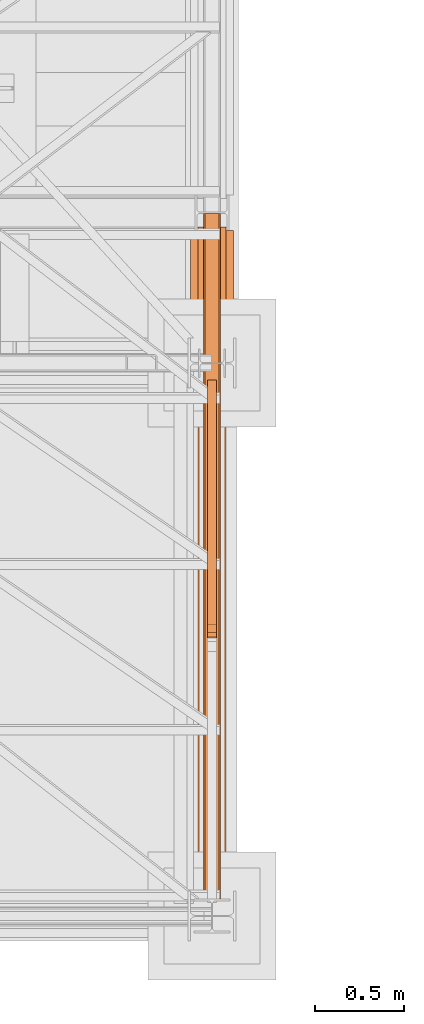
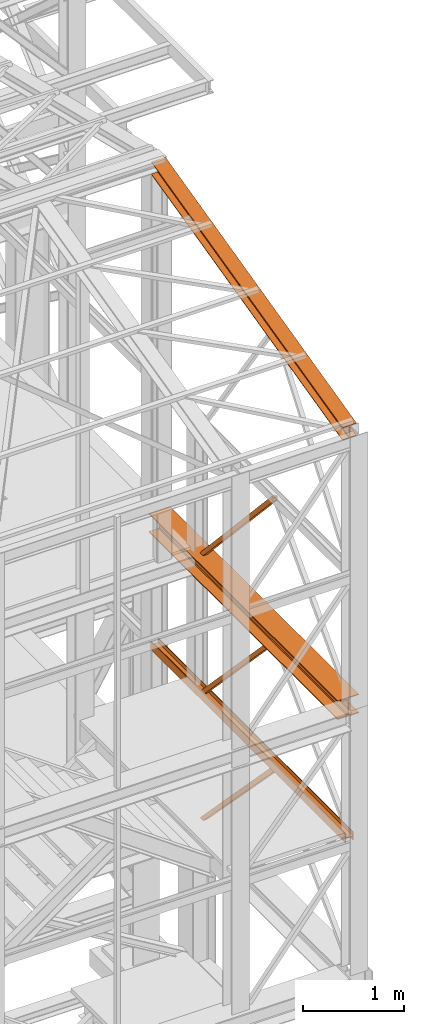
# One storey, part 58 of 208: 6 proxies.
"""IFC2X3 building model written with IfcOpenShell, lengths in millimetres."""

from ifc_helpers import new_model, entity, si_unit, converted_unit, frame, origin, origin_with_axes, place, context, subcontext, project, spatial, faceted_brep, element, save


model = new_model("IFC2X3")

# Units and contexts
model_context = context("Model", 3, precision=1e-05, world=origin())
plan_context = context("Plan", 3, precision=1e-05, world=origin())
body_context = subcontext(model_context, "Body", "Model", "MODEL_VIEW")
ifc_project = project(units=[si_unit("LENGTHUNIT", "METRE", prefix="MILLI"), converted_unit("PLANEANGLEUNIT", "DEGREE", entity("IfcPlaneAngleMeasure", 0.0174532925199433), si_unit("PLANEANGLEUNIT", "RADIAN"), dimensions=[0, 0, 0, 0, 0, 0, 0]), si_unit("AREAUNIT", "SQUARE_METRE"), si_unit("VOLUMEUNIT", "CUBIC_METRE")], contexts=[model_context, plan_context])

# Building, storey
building_placement = place(None, origin())
building = spatial("IfcBuilding", under=ifc_project, at=building_placement, CompositionType="COMPLEX")
storey_placement = place(building_placement, origin_with_axes())
storey = spatial("IfcBuildingStorey", under=building, at=storey_placement, Name="Geschoss", CompositionType="ELEMENT")

# Proxies
proxy_1_placement = place(storey_placement, frame((6650.25496814422, -25077.57437538435, 6759.989999254943), z_axis=(0.0, 0.0, 1.0), x_axis=(1.0, 0.0, 0.0)))
element("IfcBuildingElementProxy", 1, at=proxy_1_placement, inside=storey, context=body_context, shape_type="Brep", body=[
    faceted_brep([(8.010000000000218, 0.00999999999839929, 0.01000000000021828), (0.01000000000021828, 0.00999999999839929, 0.01000000000021828), (0.01000000000021828, 0.00999999999839929, 100.0100000000002), (8.010000000000218, 0.00999999999839929, 100.0100000000002), (8.010000000000218, 0.00999999999839929, 52.51000000000022), (88.01000000000022, 0.00999999999839929, 52.51000000000022), (88.01000000000022, 0.00999999999839929, 100.0100000000002), (96.00999999999931, 0.00999999999839929, 100.0100000000002), (96.00999999999931, 0.00999999999839929, 0.01000000000021828), (88.01000000000022, 0.00999999999839929, 0.01000000000021828), (88.01000000000022, 0.00999999999839929, 47.51000000000022), (8.010000000000218, 0.00999999999839929, 47.51000000000022), (0.01000000000021828, 0.00999999999839929, 0.01000000000021828), (8.010000000000218, 0.00999999999839929, 0.01000000000021828), (8.010000000000218, 3856.759984999411, 0.01000000000021828), (0.01000000000021828, 3856.759984999411, 0.01000000000021828), (0.01000000000021828, 0.00999999999839929, 100.0100000000002), (0.01000000000021828, 0.00999999999839929, 0.01000000000021828), (0.01000000000021828, 3856.759984999411, 0.01000000000021828), (0.01000000000021828, 3856.759984999411, 100.0100000000002), (8.010000000000218, 0.00999999999839929, 100.0100000000002), (0.01000000000021828, 0.00999999999839929, 100.0100000000002), (0.01000000000021828, 3856.759984999411, 100.0100000000002), (8.010000000000218, 3856.759984999411, 100.0100000000002), (8.010000000000218, 0.00999999999839929, 52.51000000000022), (8.010000000000218, 0.00999999999839929, 100.0100000000002), (8.010000000000218, 3856.759984999411, 100.0100000000002), (8.010000000000218, 3856.759984999411, 52.51000000000022), (88.01000000000022, 0.00999999999839929, 52.51000000000022), (8.010000000000218, 0.00999999999839929, 52.51000000000022), (8.010000000000218, 3856.759984999411, 52.51000000000022), (88.01000000000022, 3856.759984999411, 52.51000000000022), (88.01000000000022, 0.00999999999839929, 100.0100000000002), (88.01000000000022, 0.00999999999839929, 52.51000000000022), (88.01000000000022, 3856.759984999411, 52.51000000000022), (88.01000000000022, 3856.759984999411, 100.0100000000002), (96.00999999999931, 0.00999999999839929, 100.0100000000002), (88.01000000000022, 0.00999999999839929, 100.0100000000002), (88.01000000000022, 3856.759984999411, 100.0100000000002), (96.01000000000022, 3856.759984999411, 100.0100000000002), (96.00999999999931, 0.00999999999839929, 0.01000000000021828), (96.00999999999931, 0.00999999999839929, 100.0100000000002), (96.01000000000022, 3856.759984999411, 100.0100000000002), (96.01000000000022, 3856.759984999411, 0.01000000000021828), (88.01000000000022, 0.00999999999839929, 0.01000000000021828), (96.00999999999931, 0.00999999999839929, 0.01000000000021828), (96.01000000000022, 3856.759984999411, 0.01000000000021828), (88.01000000000022, 3856.759984999411, 0.01000000000021828), (88.01000000000022, 0.00999999999839929, 47.51000000000022), (88.01000000000022, 0.00999999999839929, 0.01000000000021828), (88.01000000000022, 3856.759984999411, 0.01000000000021828), (88.01000000000022, 3856.759984999411, 47.51000000000022), (8.010000000000218, 0.00999999999839929, 47.51000000000022), (88.01000000000022, 0.00999999999839929, 47.51000000000022), (88.01000000000022, 3856.759984999411, 47.51000000000022), (8.010000000000218, 3856.759984999411, 47.51000000000022), (8.010000000000218, 0.00999999999839929, 0.01000000000021828), (8.010000000000218, 0.00999999999839929, 47.51000000000022), (8.010000000000218, 3856.759984999411, 47.51000000000022), (8.010000000000218, 3856.759984999411, 0.01000000000021828), (8.010000000000218, 3856.759984999411, 0.01000000000021828), (8.010000000000218, 3856.759984999411, 47.51000000000022), (88.01000000000022, 3856.759984999411, 47.51000000000022), (88.01000000000022, 3856.759984999411, 0.01000000000021828), (96.01000000000022, 3856.759984999411, 0.01000000000021828), (96.01000000000022, 3856.759984999411, 100.0100000000002), (88.01000000000022, 3856.759984999411, 100.0100000000002), (88.01000000000022, 3856.759984999411, 52.51000000000022), (8.010000000000218, 3856.759984999411, 52.51000000000022), (8.010000000000218, 3856.759984999411, 100.0100000000002), (0.01000000000021828, 3856.759984999411, 100.0100000000002), (0.01000000000021828, 3856.759984999411, 0.01000000000021828)], [[[0, 1, 2, 3, 4, 5, 6, 7, 8, 9, 10, 11]], [[12, 13, 14, 15]], [[16, 17, 18, 19]], [[20, 21, 22, 23]], [[24, 25, 26, 27]], [[28, 29, 30, 31]], [[32, 33, 34, 35]], [[36, 37, 38, 39]], [[40, 41, 42, 43]], [[44, 45, 46, 47]], [[48, 49, 50, 51]], [[52, 53, 54, 55]], [[56, 57, 58, 59]], [[60, 61, 62, 63, 64, 65, 66, 67, 68, 69, 70, 71]]], orient=[[False], [False], [False], [False], [False], [False], [False], [False], [False], [False], [False], [False], [False], [False]]),
])
proxy_2_placement = place(storey_placement, frame((6673.254968156138, -23599.68394796683, 6812.489999254941), z_axis=(0.0, 0.0, 1.0), x_axis=(1.0, 0.0, 0.0)))
element("IfcBuildingElementProxy", 2, at=proxy_2_placement, inside=storey, context=body_context, shape_type="Brep", body=[
    faceted_brep([(50.01000074505828, 1442.119560065505, 0.01000000000203727), (50.01000074505737, 65.88299731319057, 1442.509998658895), (0.009999999999308784, 65.88299731319057, 1442.509998658895), (0.01000000000021828, 1442.119560065505, 0.01000000000021828), (50.01000074505828, 1374.898569487355, 0.1025547097042363), (50.01000074505737, 0.00999999999839929, 1442.509998658895), (50.01000074505737, 65.88299731319057, 1442.509998658895), (50.01000074505828, 1442.119560065505, 0.01000000000203727), (50.01000074505828, 1382.119560065505, 0.01000000000203727), (0.01000000000021828, 1374.898569487355, 0.1025547097042363), (0.009999999999308784, 0.00999999999839929, 1442.509998658893), (50.01000074505737, 0.00999999999839929, 1442.509998658895), (50.01000074505828, 1374.898569487355, 0.1025547097042363), (0.01000000000021828, 1442.119560065505, 0.01000000000021828), (0.009999999999308784, 65.88299731319057, 1442.509998658895), (0.009999999999308784, 0.00999999999839929, 1442.509998658893), (0.01000000000021828, 1374.898569487355, 0.1025547097042363), (0.01000000000021828, 1382.119560065505, 0.01000000000203727), (0.01000000000021828, 1382.119560065505, 0.01000000000203727), (0.01000000000021828, 1374.898569487355, 0.1025547097042363), (50.01000074505828, 1374.898569487355, 0.1025547097042363), (50.01000074505828, 1382.119560065505, 0.01000000000203727), (0.01000000000021828, 1442.119560065505, 0.01000000000021828), (0.01000000000021828, 1382.119560065505, 0.01000000000203727), (50.01000074505828, 1382.119560065505, 0.01000000000203727), (50.01000074505828, 1442.119560065505, 0.01000000000203727), (50.01000074505737, 65.88299731319057, 1442.509998658895), (50.01000074505737, 0.00999999999839929, 1442.509998658895), (0.009999999999308784, 0.00999999999839929, 1442.509998658893), (0.009999999999308784, 65.88299731319057, 1442.509998658895)], [[[0, 1, 2, 3]], [[4, 5, 6, 7, 8]], [[9, 10, 11, 12]], [[13, 14, 15, 16, 17]], [[18, 19, 20, 21]], [[22, 23, 24, 25]], [[26, 27, 28, 29]]], orient=[[False], [False], [False], [False], [False], [False], [False]]),
])
proxy_3_placement = place(storey_placement, frame((6578.254963760295, -25052.57438554952, 8254.989997913835), z_axis=(0.0, 0.0, 1.0), x_axis=(1.0, 0.0, 0.0)))
element("IfcBuildingElementProxy", 3, at=proxy_3_placement, inside=storey, context=body_context, shape_type="Brep", body=[
    faceted_brep([(240.0100095367425, 0.01000000000203727, 0.01000000000021828), (240.0100095367434, 3735.009993741514, 0.01000000000203727), (0.01000000000203727, 3735.009993741514, 0.01000000000021828), (0.01000000000021828, 0.01000000000203727, 0.01000000000021828), (0.01000000000021828, 0.01000000000203727, 0.01000000000021828), (0.01000000000203727, 3735.009993741514, 0.01000000000021828), (0.01000000000203727, 3735.009993741514, 12.0100019669535), (0.01000000000021828, 0.01000000000203727, 12.0100019669535), (0.01000000000021828, 0.01000000000203727, 12.0100019669535), (0.01000000000203727, 3735.009993741514, 12.0100019669535), (95.26000303983892, 3735.009993741514, 12.0100019669535), (95.2600030398371, 0.01000000000203727, 12.0100019669535), (95.2600030398371, 0.01000000000203727, 12.0100019669535), (95.26000303983892, 3735.009993741514, 12.0100019669535), (106.128449009957, 3735.009993741514, 14.18530328035376), (106.1284490099552, 0.01000000000203727, 14.18530328035376), (106.1284490099552, 0.01000000000203727, 14.18530328035376), (106.128449009957, 3735.009993741514, 14.18530328035376), (114.0846986493489, 3735.009993741514, 22.14155478239081), (114.0846986493471, 0.01000000000203727, 22.14155478239081), (114.0846986493471, 0.01000000000203727, 22.14155478239081), (114.0846986493489, 3735.009993741514, 22.14155478239081), (116.260004619362, 3735.009993741514, 33.00999982118628), (116.2600046193602, 0.01000000000203727, 33.00999982118628), (116.2600046193602, 0.01000000000203727, 33.00999982118628), (116.260004619362, 3735.009993741514, 33.00999982118628), (116.260004619362, 3735.009993741514, 197.0100043511357), (116.2600046193602, 0.01000000000203727, 197.0100043511357), (116.2600046193602, 0.01000000000203727, 197.0100043511357), (116.260004619362, 3735.009993741514, 197.0100043511357), (114.0846986493489, 3735.009993741514, 207.8784493899311), (114.0846986493471, 0.00999999999839929, 207.8784493899311), (114.0846986493471, 0.00999999999839929, 207.8784493899311), (114.0846986493489, 3735.009993741514, 207.8784493899311), (106.128449009957, 3735.009993741514, 215.8347008919682), (106.1284490099552, 0.01000000000203727, 215.8347008919682), (106.1284490099552, 0.01000000000203727, 215.8347008919682), (106.128449009957, 3735.009993741514, 215.8347008919682), (95.26000303983892, 3735.009993741514, 218.0100022053684), (95.2600030398371, 0.01000000000203727, 218.0100022053684), (95.2600030398371, 0.01000000000203727, 218.0100022053684), (95.26000303983892, 3735.009993741514, 218.0100022053684), (0.01000000000203727, 3735.009993741514, 218.0100022053684), (0.01000000000021828, 0.01000000000203727, 218.0100022053684), (0.01000000000021828, 0.01000000000203727, 218.0100022053684), (0.01000000000203727, 3735.009993741514, 218.0100022053684), (0.01000000000203727, 3735.009993741514, 230.0100041723217), (0.01000000000021828, 0.01000000000203727, 230.0100041723217), (0.01000000000021828, 0.01000000000203727, 230.0100041723217), (0.01000000000203727, 3735.009993741514, 230.0100041723217), (240.0100095367434, 3735.009993741514, 230.0100041723217), (240.0100095367425, 0.01000000000203727, 230.0100041723217), (240.0100095367425, 0.01000000000203727, 230.0100041723217), (240.0100095367434, 3735.009993741514, 230.0100041723217), (240.0100095367434, 3735.009993741514, 218.0100022053684), (240.0100095367425, 0.01000000000203727, 218.0100022053684), (240.0100095367425, 0.01000000000203727, 218.0100022053684), (240.0100095367434, 3735.009993741514, 218.0100022053684), (144.7600064969065, 3735.009993741514, 218.0100022053684), (144.7600064969056, 0.01000000000203727, 218.0100022053684), (144.7600064969056, 0.01000000000203727, 218.0100022053684), (144.7600064969065, 3735.009993741514, 218.0100022053684), (133.8915605267885, 3735.009993741514, 215.8347008919664), (133.8915605267875, 0.01000000000203727, 215.8347008919664), (133.8915605267875, 0.01000000000203727, 215.8347008919664), (133.8915605267885, 3735.009993741514, 215.8347008919664), (125.9353108873966, 3735.009993741514, 207.8784493899311), (125.9353108873956, 0.01000000000203727, 207.8784493899311), (125.9353108873956, 0.01000000000203727, 207.8784493899311), (125.9353108873966, 3735.009993741514, 207.8784493899311), (123.7600049173834, 3735.009993741514, 197.0100043511375), (123.7600049173825, 0.01000000000203727, 197.0100043511357), (123.7600049173825, 0.01000000000203727, 197.0100043511357), (123.7600049173834, 3735.009993741514, 197.0100043511375), (123.7600049173834, 3735.009993741514, 33.00999982118628), (123.7600049173825, 0.01000000000203727, 33.00999982118628), (123.7600049173825, 0.01000000000203727, 33.00999982118628), (123.7600049173834, 3735.009993741514, 33.00999982118628), (125.9353108873966, 3735.009993741514, 22.14155478239081), (125.9353108873966, 0.01000000000203727, 22.14155478239081), (125.9353108873966, 0.01000000000203727, 22.14155478239081), (125.9353108873966, 3735.009993741514, 22.14155478239081), (133.8915605267885, 3735.009993741514, 14.18530328035376), (133.8915605267875, 0.01000000000203727, 14.18530328035376), (133.8915605267875, 0.01000000000203727, 14.18530328035376), (133.8915605267885, 3735.009993741514, 14.18530328035376), (144.7600064969065, 3735.009993741514, 12.0100019669535), (144.7600064969056, 0.01000000000203727, 12.0100019669535), (144.7600064969056, 0.01000000000203727, 12.0100019669535), (144.7600064969065, 3735.009993741514, 12.0100019669535), (240.0100095367434, 3735.009993741514, 12.0100019669535), (240.0100095367425, 0.00999999999839929, 12.0100019669535), (240.0100095367425, 0.00999999999839929, 12.0100019669535), (240.0100095367434, 3735.009993741514, 12.0100019669535), (240.0100095367434, 3735.009993741514, 0.01000000000203727), (240.0100095367425, 0.01000000000203727, 0.01000000000021828), (240.0100095367425, 0.01000000000203727, 0.01000000000021828), (0.01000000000021828, 0.01000000000203727, 0.01000000000021828), (0.01000000000021828, 0.01000000000203727, 12.0100019669535), (95.2600030398371, 0.01000000000203727, 12.0100019669535), (106.1284490099552, 0.01000000000203727, 14.18530328035376), (114.0846986493471, 0.01000000000203727, 22.14155478239081), (116.2600046193602, 0.01000000000203727, 33.00999982118628), (116.2600046193602, 0.01000000000203727, 197.0100043511357), (114.0846986493471, 0.00999999999839929, 207.8784493899311), (106.1284490099552, 0.01000000000203727, 215.8347008919682), (95.2600030398371, 0.01000000000203727, 218.0100022053684), (0.01000000000021828, 0.01000000000203727, 218.0100022053684), (0.01000000000021828, 0.01000000000203727, 230.0100041723217), (240.0100095367425, 0.01000000000203727, 230.0100041723217), (240.0100095367425, 0.01000000000203727, 218.0100022053684), (144.7600064969056, 0.01000000000203727, 218.0100022053684), (133.8915605267875, 0.01000000000203727, 215.8347008919664), (125.9353108873956, 0.01000000000203727, 207.8784493899311), (123.7600049173825, 0.01000000000203727, 197.0100043511357), (123.7600049173825, 0.01000000000203727, 33.00999982118628), (125.9353108873966, 0.01000000000203727, 22.14155478239081), (133.8915605267875, 0.01000000000203727, 14.18530328035376), (144.7600064969056, 0.01000000000203727, 12.0100019669535), (240.0100095367425, 0.00999999999839929, 12.0100019669535), (240.0100095367434, 3735.009993741514, 0.01000000000203727), (240.0100095367434, 3735.009993741514, 12.0100019669535), (144.7600064969065, 3735.009993741514, 12.0100019669535), (133.8915605267885, 3735.009993741514, 14.18530328035376), (125.9353108873966, 3735.009993741514, 22.14155478239081), (123.7600049173834, 3735.009993741514, 33.00999982118628), (123.7600049173834, 3735.009993741514, 197.0100043511375), (125.9353108873966, 3735.009993741514, 207.8784493899311), (133.8915605267885, 3735.009993741514, 215.8347008919664), (144.7600064969065, 3735.009993741514, 218.0100022053684), (240.0100095367434, 3735.009993741514, 218.0100022053684), (240.0100095367434, 3735.009993741514, 230.0100041723217), (0.01000000000203727, 3735.009993741514, 230.0100041723217), (0.01000000000203727, 3735.009993741514, 218.0100022053684), (95.26000303983892, 3735.009993741514, 218.0100022053684), (106.128449009957, 3735.009993741514, 215.8347008919682), (114.0846986493489, 3735.009993741514, 207.8784493899311), (116.260004619362, 3735.009993741514, 197.0100043511357), (116.260004619362, 3735.009993741514, 33.00999982118628), (114.0846986493489, 3735.009993741514, 22.14155478239081), (106.128449009957, 3735.009993741514, 14.18530328035376), (95.26000303983892, 3735.009993741514, 12.0100019669535), (0.01000000000203727, 3735.009993741514, 12.0100019669535), (0.01000000000203727, 3735.009993741514, 0.01000000000021828)], [[[0, 1, 2, 3]], [[4, 5, 6, 7]], [[8, 9, 10, 11]], [[12, 13, 14, 15]], [[16, 17, 18, 19]], [[20, 21, 22, 23]], [[24, 25, 26, 27]], [[28, 29, 30, 31]], [[32, 33, 34, 35]], [[36, 37, 38, 39]], [[40, 41, 42, 43]], [[44, 45, 46, 47]], [[48, 49, 50, 51]], [[52, 53, 54, 55]], [[56, 57, 58, 59]], [[60, 61, 62, 63]], [[64, 65, 66, 67]], [[68, 69, 70, 71]], [[72, 73, 74, 75]], [[76, 77, 78, 79]], [[80, 81, 82, 83]], [[84, 85, 86, 87]], [[88, 89, 90, 91]], [[92, 93, 94, 95]], [[96, 97, 98, 99, 100, 101, 102, 103, 104, 105, 106, 107, 108, 109, 110, 111, 112, 113, 114, 115, 116, 117, 118, 119]], [[120, 121, 122, 123, 124, 125, 126, 127, 128, 129, 130, 131, 132, 133, 134, 135, 136, 137, 138, 139, 140, 141, 142, 143]]], orient=[[False], [False], [False], [False], [False], [False], [False], [False], [False], [False], [False], [False], [False], [False], [False], [False], [False], [False], [False], [False], [False], [False], [False], [False], [False], [False]]),
])
proxy_4_placement = place(storey_placement, frame((6618.254966591512, -25077.57437538435, 11628.70515179705), z_axis=(0.0, 0.0, 1.0), x_axis=(1.0, 0.0, 0.0)))
element("IfcBuildingElementProxy", 4, at=proxy_4_placement, inside=storey, context=body_context, shape_type="Brep", body=[
    faceted_brep([(160.01001132489, 3780.009979404025, 1074.775244917653), (160.01001132488, 0.00999999999839929, 156.4315054631916), (0.01000000000021828, 0.00999999999839929, 156.4315054631916), (0.01000000000749424, 3780.009979404025, 1074.775244917653), (0.01000000000749424, 3780.009979404025, 1074.775244917653), (0.01000000000021828, 0.00999999999839929, 156.4315054631916), (0.01000000000021828, 0.00999999999839929, 147.1697029728093), (0.01000000000749424, 3780.009979404025, 1065.513442427271), (0.01000000000749424, 3780.009979404025, 1065.513442427271), (0.01000000000021828, 0.00999999999839929, 147.1697029728093), (62.01000457465671, 0.00999999999839929, 147.1697029728093), (62.01000457466307, 3780.009979404025, 1065.513442427271), (62.01000457466307, 3780.009979404025, 1065.513442427271), (62.01000457465671, 0.00999999999839929, 147.1697029728093), (69.77318079977886, 0.00999999999839929, 145.5707163655079), (69.77318079978886, 3780.009979404025, 1063.914455819968), (69.77318079978886, 3780.009979404025, 1063.914455819968), (69.77318079977886, 0.00999999999839929, 145.5707163655079), (75.45621545821086, 0.00999999999839929, 139.7223691397903), (75.45621545822178, 3780.009979404025, 1058.066108594254), (75.45621545822178, 3780.009979404025, 1058.066108594254), (75.45621545821086, 0.00999999999839929, 139.7223691397903), (77.0100056363608, 0.00999999999839929, 131.7333744340358), (77.0100056363708, 3780.009979404025, 1050.077113888498), (77.0100056363708, 3780.009979404025, 1050.077113888498), (77.0100056363608, 0.00999999999839929, 131.7333744340358), (77.0100056363608, 0.00999999999839929, 24.70813486281259), (77.0100056363708, 3780.009979404025, 943.0518743172743), (77.0100056363708, 3780.009979404025, 943.0518743172743), (77.0100056363608, 0.00999999999839929, 24.70813486281259), (75.45621545821086, 0.00999999999839929, 16.71913632339965), (75.45621545822087, 3780.009979404025, 935.0628757778613), (75.45621545822087, 3780.009979404025, 935.0628757778613), (75.45621545821086, 0.00999999999839929, 16.71913632339965), (69.77318079977886, 0.00999999999839929, 10.87078909768752), (69.77318079978886, 3780.009979404025, 929.2145285521474), (69.77318079978886, 3780.009979404025, 929.2145285521474), (69.77318079977886, 0.00999999999839929, 10.87078909768752), (62.01000457465307, 0.00999999999839929, 9.27180249038247), (62.01000457466307, 3780.009979404025, 927.6155419448442), (62.01000457466307, 3780.009979404025, 927.6155419448442), (62.01000457465307, 0.00999999999839929, 9.27180249038247), (0.01000000000021828, 0.00999999999839929, 9.27180249038247), (0.01000000000749424, 3780.009979404025, 927.6155419448423), (0.01000000000749424, 3780.009979404025, 927.6155419448423), (0.01000000000021828, 0.00999999999839929, 9.27180249038247), (0.01000000000021828, 0.00999999999839929, 0.01000000000021828), (0.01000000000658474, 3780.009979404025, 918.3537394544601), (0.01000000000658474, 3780.009979404025, 918.3537394544601), (0.01000000000021828, 0.00999999999839929, 0.01000000000021828), (160.0100113248827, 0.00999999999839929, 0.01000000000021828), (160.01001132489, 3780.009979404025, 918.3537394544619), (160.01001132489, 3780.009979404025, 918.3537394544619), (160.0100113248827, 0.00999999999839929, 0.01000000000021828), (160.0100113248836, 0.00999999999839929, 9.27180249038065), (160.01001132489, 3780.009979404025, 927.6155419448423), (160.01001132489, 3780.009979404025, 927.6155419448423), (160.0100113248836, 0.00999999999839929, 9.27180249038065), (98.0100067502226, 0.00999999999839929, 9.27180249038247), (98.0100067502326, 3780.009979404025, 927.6155419448423), (98.0100067502326, 3780.009979404025, 927.6155419448423), (98.0100067502226, 0.00999999999839929, 9.27180249038247), (90.24683052509681, 0.00999999999839929, 10.87078909768752), (90.24683052510682, 3780.009979404025, 929.2145285521474), (90.24683052510682, 3780.009979404025, 929.2145285521474), (90.24683052509681, 0.00999999999839929, 10.87078909768752), (84.5637958666648, 0.00999999999839929, 16.71913632339783), (84.56379586667481, 3780.009979404025, 935.0628757778613), (84.56379586667481, 3780.009979404025, 935.0628757778613), (84.5637958666648, 0.00999999999839929, 16.71913632339783), (83.01000568851487, 0.00999999999839929, 24.70813486281077), (83.01000568852487, 3780.009979404025, 943.0518743172743), (83.01000568852487, 3780.009979404025, 943.0518743172743), (83.01000568851487, 0.00999999999839929, 24.70813486281077), (83.01000568851487, 0.00999999999839929, 131.733374434034), (83.01000568852487, 3780.009979404025, 1050.077113888496), (83.01000568852487, 3780.009979404025, 1050.077113888496), (83.01000568851487, 0.00999999999839929, 131.733374434034), (84.5637958666648, 0.00999999999839929, 139.7223691397903), (84.56379586667572, 3780.009979404025, 1058.066108594254), (84.56379586667572, 3780.009979404025, 1058.066108594254), (84.5637958666648, 0.00999999999839929, 139.7223691397903), (90.24683052509681, 0.00999999999839929, 145.5707163655079), (90.24683052510773, 3780.009979404025, 1063.914455819968), (90.24683052510773, 3780.009979404025, 1063.914455819968), (90.24683052509681, 0.00999999999839929, 145.5707163655079), (98.0100067502226, 0.00999999999839929, 147.1697029728093), (98.0100067502326, 3780.009979404025, 1065.513442427271), (98.0100067502326, 3780.009979404025, 1065.513442427271), (98.0100067502226, 0.00999999999839929, 147.1697029728093), (160.0100113248827, 0.00999999999839929, 147.1697029728093), (160.01001132489, 3780.009979404025, 1065.513442427271), (160.01001132489, 3780.009979404025, 1065.513442427271), (160.0100113248827, 0.00999999999839929, 147.1697029728093), (160.01001132488, 0.00999999999839929, 156.4315054631916), (160.01001132489, 3780.009979404025, 1074.775244917653), (0.01000000000749424, 3780.009979404025, 1074.775244917653), (0.01000000000749424, 3780.009979404025, 1065.513442427271), (62.01000457466307, 3780.009979404025, 1065.513442427271), (69.77318079978886, 3780.009979404025, 1063.914455819968), (75.45621545822178, 3780.009979404025, 1058.066108594254), (77.0100056363708, 3780.009979404025, 1050.077113888498), (77.0100056363708, 3780.009979404025, 943.0518743172743), (75.45621545822087, 3780.009979404025, 935.0628757778613), (69.77318079978886, 3780.009979404025, 929.2145285521474), (62.01000457466307, 3780.009979404025, 927.6155419448442), (0.01000000000749424, 3780.009979404025, 927.6155419448423), (0.01000000000658474, 3780.009979404025, 918.3537394544601), (160.01001132489, 3780.009979404025, 918.3537394544619), (160.01001132489, 3780.009979404025, 927.6155419448423), (98.0100067502326, 3780.009979404025, 927.6155419448423), (90.24683052510682, 3780.009979404025, 929.2145285521474), (84.56379586667481, 3780.009979404025, 935.0628757778613), (83.01000568852487, 3780.009979404025, 943.0518743172743), (83.01000568852487, 3780.009979404025, 1050.077113888496), (84.56379586667572, 3780.009979404025, 1058.066108594254), (90.24683052510773, 3780.009979404025, 1063.914455819968), (98.0100067502326, 3780.009979404025, 1065.513442427271), (160.01001132489, 3780.009979404025, 1065.513442427271), (160.01001132489, 3780.009979404025, 1074.775244917653), (160.01001132488, 0.00999999999839929, 156.4315054631916), (160.0100113248827, 0.00999999999839929, 147.1697029728093), (98.0100067502226, 0.00999999999839929, 147.1697029728093), (90.24683052509681, 0.00999999999839929, 145.5707163655079), (84.5637958666648, 0.00999999999839929, 139.7223691397903), (83.01000568851487, 0.00999999999839929, 131.733374434034), (83.01000568851487, 0.00999999999839929, 24.70813486281077), (84.5637958666648, 0.00999999999839929, 16.71913632339783), (90.24683052509681, 0.00999999999839929, 10.87078909768752), (98.0100067502226, 0.00999999999839929, 9.27180249038247), (160.0100113248836, 0.00999999999839929, 9.27180249038065), (160.0100113248827, 0.00999999999839929, 0.01000000000021828), (0.01000000000021828, 0.00999999999839929, 0.01000000000021828), (0.01000000000021828, 0.00999999999839929, 9.27180249038247), (62.01000457465307, 0.00999999999839929, 9.27180249038247), (69.77318079977886, 0.00999999999839929, 10.87078909768752), (75.45621545821086, 0.00999999999839929, 16.71913632339965), (77.0100056363608, 0.00999999999839929, 24.70813486281259), (77.0100056363608, 0.00999999999839929, 131.7333744340358), (75.45621545821086, 0.00999999999839929, 139.7223691397903), (69.77318079977886, 0.00999999999839929, 145.5707163655079), (62.01000457465671, 0.00999999999839929, 147.1697029728093), (0.01000000000021828, 0.00999999999839929, 147.1697029728093), (0.01000000000021828, 0.00999999999839929, 156.4315054631916)], [[[0, 1, 2, 3]], [[4, 5, 6, 7]], [[8, 9, 10, 11]], [[12, 13, 14, 15]], [[16, 17, 18, 19]], [[20, 21, 22, 23]], [[24, 25, 26, 27]], [[28, 29, 30, 31]], [[32, 33, 34, 35]], [[36, 37, 38, 39]], [[40, 41, 42, 43]], [[44, 45, 46, 47]], [[48, 49, 50, 51]], [[52, 53, 54, 55]], [[56, 57, 58, 59]], [[60, 61, 62, 63]], [[64, 65, 66, 67]], [[68, 69, 70, 71]], [[72, 73, 74, 75]], [[76, 77, 78, 79]], [[80, 81, 82, 83]], [[84, 85, 86, 87]], [[88, 89, 90, 91]], [[92, 93, 94, 95]], [[96, 97, 98, 99, 100, 101, 102, 103, 104, 105, 106, 107, 108, 109, 110, 111, 112, 113, 114, 115, 116, 117, 118, 119]], [[120, 121, 122, 123, 124, 125, 126, 127, 128, 129, 130, 131, 132, 133, 134, 135, 136, 137, 138, 139, 140, 141, 142, 143]]], orient=[[False], [False], [False], [False], [False], [False], [False], [False], [False], [False], [False], [False], [False], [False], [False], [False], [False], [False], [False], [False], [False], [False], [False], [False], [False], [False]]),
])
proxy_5_placement = place(storey_placement, frame((6673.254968156138, -23609.99467518261, 5284.990005364415), z_axis=(0.0, 0.0, 1.0), x_axis=(1.0, 0.0, 0.0)))
element("IfcBuildingElementProxy", 5, at=proxy_5_placement, inside=storey, context=body_context, shape_type="Brep", body=[
    faceted_brep([(0.01000000000021828, 0.2928158898466791, 1428.866375912856), (50.01000074505828, 0.2928158898466791, 1428.866375912854), (50.01000074505828, 1388.642874963796, 0.01000000000021828), (0.01000000000021828, 1388.642874963796, 0.01000000000021828), (50.01000074505828, 32.15127611343269, 1474.917439180826), (50.01000074505828, 1452.430287281284, 0.01000000000021828), (50.01000074505828, 1388.642874963796, 0.01000000000021828), (50.01000074505828, 0.2928158898466791, 1428.866375912854), (50.01000074505828, 0.00999999999839929, 1475.009993890528), (0.01000000000021828, 32.15127611343269, 1474.917439180826), (0.01000000000021828, 1452.430287281284, 0.01000000000021828), (50.01000074505828, 1452.430287281284, 0.01000000000021828), (50.01000074505828, 32.15127611343269, 1474.917439180826), (0.01000000000021828, 0.00999999999839929, 1475.009993890528), (0.01000000000021828, 0.2928158898466791, 1428.866375912856), (0.01000000000021828, 1388.642874963796, 0.01000000000021828), (0.01000000000021828, 1452.430287281284, 0.01000000000021828), (0.01000000000021828, 32.15127611343269, 1474.917439180826), (50.01000074505828, 0.00999999999839929, 1475.009993890528), (0.01000000000021828, 0.00999999999839929, 1475.009993890528), (0.01000000000021828, 32.15127611343269, 1474.917439180826), (50.01000074505828, 32.15127611343269, 1474.917439180826), (50.01000074505828, 0.2928158898466791, 1428.866375912854), (0.01000000000021828, 0.2928158898466791, 1428.866375912856), (0.01000000000021828, 0.00999999999839929, 1475.009993890528), (50.01000074505828, 0.00999999999839929, 1475.009993890528), (0.01000000000021828, 1388.642874963796, 0.01000000000021828), (50.01000074505828, 1388.642874963796, 0.01000000000021828), (50.01000074505828, 1452.430287281284, 0.01000000000021828), (0.01000000000021828, 1452.430287281284, 0.01000000000021828)], [[[0, 1, 2, 3]], [[4, 5, 6, 7, 8]], [[9, 10, 11, 12]], [[13, 14, 15, 16, 17]], [[18, 19, 20, 21]], [[22, 23, 24, 25]], [[26, 27, 28, 29]]], orient=[[False], [False], [False], [False], [False], [False], [False]]),
])
proxy_6_placement = place(storey_placement, frame((6673.254968156134, -23609.75807774477, 8484.990002086159), z_axis=(0.0, 0.0, 1.0), x_axis=(1.0, 0.0, 0.0)))
element("IfcBuildingElementProxy", 6, at=proxy_6_placement, inside=storey, context=body_context, shape_type="Brep", body=[
    faceted_brep([(0.01000000000112777, 0.00999999999839929, 1497.729951931144), (50.01000074505919, 0.00999999999839929, 1497.72995193114), (50.01000074505828, 1388.406277525959, 0.00999999999839929), (0.01000000000021828, 1388.406277525959, 0.00999999999839929), (50.01000074505919, 31.9146786755955, 1542.509998658894), (50.01000074505828, 1452.193689843443, 0.00999999999839929), (50.01000074505828, 1388.406277525959, 0.00999999999839929), (50.01000074505919, 0.00999999999839929, 1497.72995193114), (50.01000074505919, 0.1938854341788101, 1542.602553368595), (0.01000000000112777, 31.9146786755955, 1542.509998658894), (0.01000000000021828, 1452.193689843443, 0.00999999999839929), (50.01000074505828, 1452.193689843443, 0.00999999999839929), (50.01000074505919, 31.9146786755955, 1542.509998658894), (0.01000000000112777, 0.1938854341788101, 1542.602553368595), (0.01000000000112777, 0.00999999999839929, 1497.729951931144), (0.01000000000021828, 1388.406277525959, 0.00999999999839929), (0.01000000000021828, 1452.193689843443, 0.00999999999839929), (0.01000000000112777, 31.9146786755955, 1542.509998658894), (50.01000074505919, 0.1938854341788101, 1542.602553368595), (0.01000000000112777, 0.1938854341788101, 1542.602553368595), (0.01000000000112777, 31.9146786755955, 1542.509998658894), (50.01000074505919, 31.9146786755955, 1542.509998658894), (50.01000074505919, 0.00999999999839929, 1497.72995193114), (0.01000000000112777, 0.00999999999839929, 1497.729951931144), (0.01000000000112777, 0.1938854341788101, 1542.602553368595), (50.01000074505919, 0.1938854341788101, 1542.602553368595), (0.01000000000021828, 1388.406277525959, 0.00999999999839929), (50.01000074505828, 1388.406277525959, 0.00999999999839929), (50.01000074505828, 1452.193689843443, 0.00999999999839929), (0.01000000000021828, 1452.193689843443, 0.00999999999839929)], [[[0, 1, 2, 3]], [[4, 5, 6, 7, 8]], [[9, 10, 11, 12]], [[13, 14, 15, 16, 17]], [[18, 19, 20, 21]], [[22, 23, 24, 25]], [[26, 27, 28, 29]]], orient=[[False], [False], [False], [False], [False], [False], [False]]),
])

save(model, "model.ifc")
